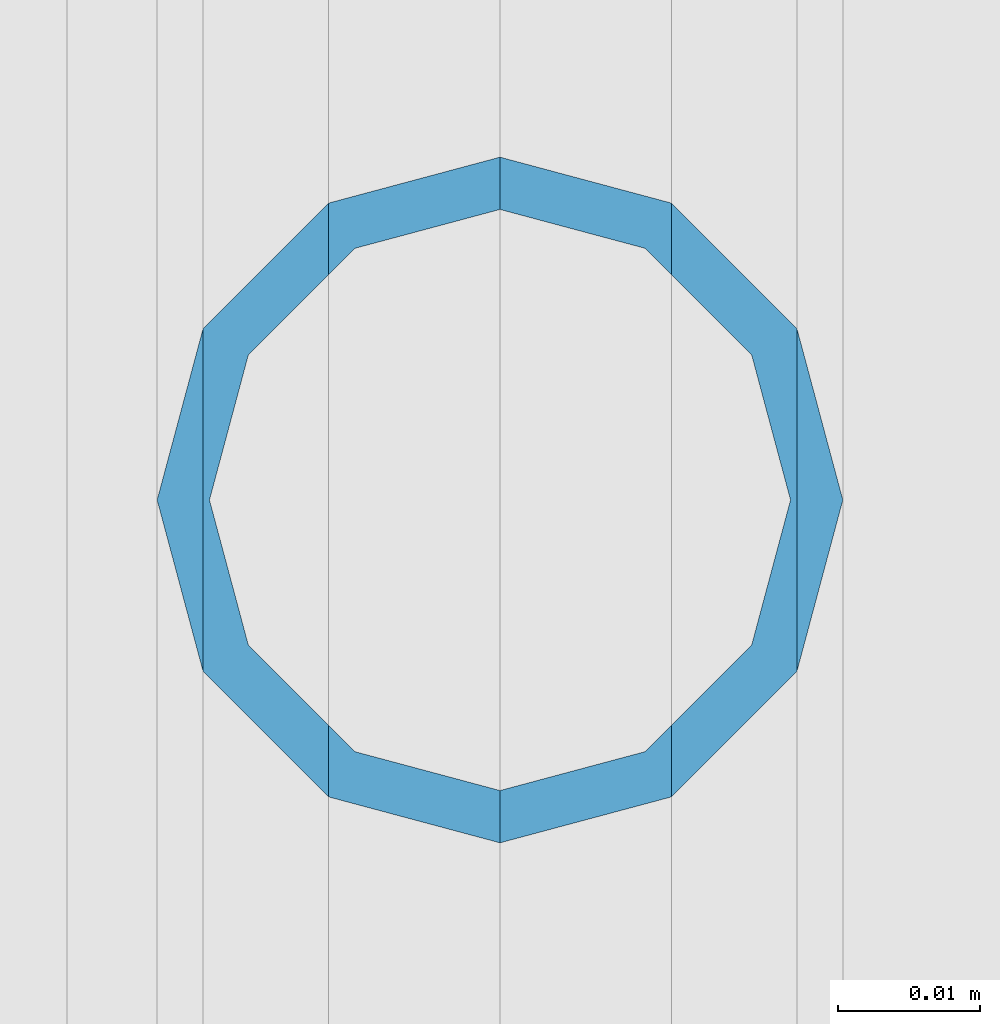
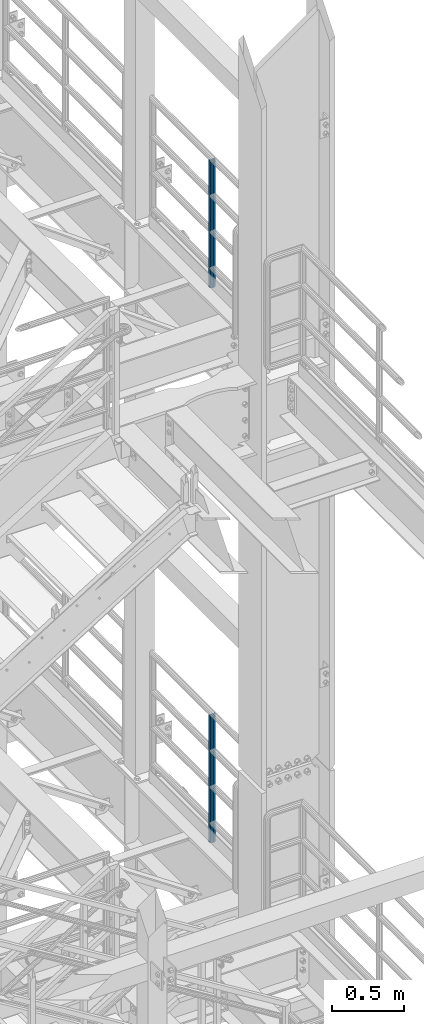
# One storey, part 669 of 1876: 2 columns, 2 elements without a shape of their own.
"""IFC2X3 building model written with IfcOpenShell, lengths in millimetres."""

from ifc_helpers import new_model, si_unit, frame, origin_with_axes, place, context, subcontext, project, spatial, faceted_brep, material, type_object, element, aggregate, save


model = new_model("IFC2X3")

# Units and contexts
model_context = context("Model", 3, precision=1e-05, world=origin_with_axes())
body_context = subcontext(model_context, "Body", "Model", "MODEL_VIEW")
ifc_project = project(units=[si_unit("LENGTHUNIT", "METRE", prefix="MILLI"), si_unit("AREAUNIT", "SQUARE_METRE"), si_unit("VOLUMEUNIT", "CUBIC_METRE"), si_unit("MASSUNIT", "GRAM", prefix="KILO"), si_unit("TIMEUNIT", "SECOND"), si_unit("PLANEANGLEUNIT", "RADIAN"), si_unit("SOLIDANGLEUNIT", "STERADIAN"), si_unit("THERMODYNAMICTEMPERATUREUNIT", "DEGREE_CELSIUS"), si_unit("LUMINOUSINTENSITYUNIT", "LUMEN")], contexts=[model_context])

# Site, building, storey
site_placement = place(None, origin_with_axes())
site = spatial("IfcSite", under=ifc_project, at=site_placement, CompositionType="ELEMENT")
building_placement = place(site_placement, origin_with_axes())
building = spatial("IfcBuilding", under=site, at=building_placement, Name="Undefined", CompositionType="ELEMENT")
storey_placement = place(building_placement, origin_with_axes())
storey = spatial("IfcBuildingStorey", under=building, at=storey_placement, Name="Undefined", CompositionType="ELEMENT", Elevation=0.0)

# Assembly, column
assembly_1_placement = place(storey_placement, origin_with_axes())
assembly_1 = element("IfcElementAssembly", 1, at=assembly_1_placement, inside=storey, Name="RAIL", AssemblyPlace="NOTDEFINED", PredefinedType="RIGID_FRAME")
ifc_material = material()
column_type = type_object("IfcColumnType", Name="PIPE1-1/2SCH40", PredefinedType="NOTDEFINED")
column_1_placement = place(assembly_1_placement, frame((7620.0, -3542.7031, 17983.2), z_axis=(0.0, 1.0, 0.0), x_axis=(0.0, 0.0, 1.0)))
column_1 = element("IfcColumn", 2, at=column_1_placement, type_object=column_type, material=ifc_material, Name="POST", ObjectType="PIPE1-1/2SCH40", context=body_context, shape_type="Brep", body=[
    faceted_brep([(1055.42780700668, -12.0650000000001, 20.8971929933186), (1055.42780700668, -12.0650000000001, 15.8661214311805), (1054.93437856882, -10.2235000000001, 17.7076214311801), (1052.195, 0.0, 20.4470000000001), (1052.195, 0.0, 24.1300000000001), (1054.93437856882, 10.2235000000001, 17.7076214311801), (1055.42780700668, 12.0650000000001, 15.8661214311805), (1055.42780700668, 12.0650000000001, 20.8971929933186), (1076.325, 24.1300000000001, 0.0), (1064.26, 20.8971929933184, 12.0649999999996), (1064.25999999999, 20.8971929933186, -12.0649999999996), (1061.07042843786, 17.7076214311803, 10.2235000000001), (1063.80980700668, 20.4469999999999, 0.0), (1061.07042843786, 17.7076214311803, -10.2235000000001), (1055.42780700668, 12.0650000000001, -15.8661214311805), (1055.42780700667, 12.0649999999996, -20.8971929933186), (1054.93437856882, 10.2235000000001, -17.7076214311801), (1052.195, 0.0, -20.4470000000001), (1052.19499999999, 0.0, -24.1300000000001), (1055.42780700668, -12.0650000000001, -15.8661214311805), (1055.42780700667, -12.0649999999996, -20.8971929933186), (1054.93437856882, -10.2235000000001, -17.7076214311801), (1076.325, -24.1300000000001, 0.0), (1064.25999999999, -20.8971929933186, -12.0649999999996), (1064.26, -20.8971929933184, 12.0649999999996), (1061.07042843786, -17.7076214311803, -10.2235000000001), (1063.80980700668, -20.4469999999999, 0.0), (1061.07042843786, -17.7076214311803, 10.2235000000001), (0.0, -20.8971929933184, -12.0649999999996), (0.0, -12.0650000000001, -20.8971929933186), (-1.45519152283669e-11, 0.0, -24.130000000001), (0.0, 12.0650000000001, -20.8971929933186), (0.0, 20.8971929933184, -12.0649999999996), (0.0, 24.1299999999992, 0.0), (0.0, 20.8971929933184, 12.0649999999996), (0.0, 12.0650000000001, 20.8971929933186), (-1.45519152283669e-11, 0.0, 24.130000000001), (0.0, -12.0650000000001, 20.8971929933186), (0.0, -20.8971929933184, 12.0649999999996), (0.0, -24.1299999999992, 0.0), (0.0, -17.7076214311803, -10.2235000000001), (0.0, -10.2235000000001, -17.7076214311801), (-1.45519152283669e-11, 0.0, -20.4470000000001), (0.0, 10.2235000000001, -17.7076214311801), (0.0, 17.7076214311803, -10.2235000000001), (0.0, 20.4469999999999, 0.0), (0.0, 17.7076214311803, 10.2235000000001), (0.0, 10.2235000000001, 17.7076214311801), (-1.45519152283669e-11, 0.0, 20.4470000000001), (0.0, -10.2235000000001, 17.7076214311801), (0.0, -17.7076214311803, 10.2235000000001), (0.0, -20.4469999999999, 0.0)], [[[0, 1, 2, 3, 4]], [[4, 3, 5, 6, 7]], [[8, 9, 10]], [[7, 6, 11, 12, 13, 14, 15, 10, 9]], [[16, 17, 18, 15, 14]], [[19, 20, 18, 17, 21]], [[22, 23, 24]], [[24, 23, 20, 19, 25, 26, 27, 1, 0]], [[28, 29, 20, 23]], [[29, 30, 18, 20]], [[30, 31, 15, 18]], [[31, 32, 10, 15]], [[32, 33, 8, 10]], [[33, 34, 9, 8]], [[34, 35, 7, 9]], [[35, 36, 4, 7]], [[36, 37, 0, 4]], [[37, 38, 24, 0]], [[38, 39, 22, 24]], [[39, 28, 23, 22]], [[38, 37, 36, 35, 34, 33, 32, 31, 30, 29, 28, 39], [40, 41, 42, 43, 44, 45, 46, 47, 48, 49, 50, 51]], [[40, 51, 26, 25]], [[21, 41, 40, 25, 19]], [[42, 41, 21, 17]], [[43, 42, 17, 16]], [[44, 43, 16, 14, 13]], [[45, 44, 13, 12]], [[46, 45, 12, 11]], [[5, 47, 46, 11, 6]], [[48, 47, 5, 3]], [[49, 48, 3, 2]], [[50, 49, 2, 1, 27]], [[51, 50, 27, 26]]]),
])
aggregate(assembly_1, [column_1])

assembly_2_placement = place(storey_placement, origin_with_axes())
assembly_2 = element("IfcElementAssembly", 3, at=assembly_2_placement, inside=storey, Name="RAIL", AssemblyPlace="NOTDEFINED", PredefinedType="RIGID_FRAME")
column_2_placement = place(assembly_2_placement, frame((7620.0, -3542.70310000001, 13309.6), z_axis=(0.0, 1.0, 0.0), x_axis=(0.0, 0.0, 1.0)))
column_2 = element("IfcColumn", 4, at=column_2_placement, type_object=column_type, material=ifc_material, Name="POST", ObjectType="PIPE1-1/2SCH40", context=body_context, shape_type="Brep", body=[
    faceted_brep([(1055.42780700668, -12.0650000000001, 20.8971929933186), (1055.42780700668, -12.0650000000001, 15.8661214311805), (1054.93437856882, -10.2235000000001, 17.7076214311801), (1052.195, 0.0, 20.4470000000001), (1052.195, 0.0, 24.1300000000001), (1054.93437856882, 10.2235000000001, 17.7076214311801), (1055.42780700668, 12.0650000000001, 15.8661214311805), (1055.42780700668, 12.0650000000001, 20.8971929933186), (1076.325, 24.1300000000001, 0.0), (1064.26, 20.8971929933184, 12.0649999999996), (1064.25999999999, 20.8971929933186, -12.0649999999996), (1061.07042843786, 17.7076214311803, 10.2235000000001), (1063.80980700668, 20.4469999999999, 0.0), (1061.07042843786, 17.7076214311803, -10.2235000000001), (1055.42780700668, 12.0650000000001, -15.8661214311805), (1055.42780700667, 12.0649999999996, -20.8971929933186), (1054.93437856882, 10.2235000000001, -17.7076214311801), (1052.195, 0.0, -20.4470000000001), (1052.19499999999, 0.0, -24.1300000000001), (1055.42780700668, -12.0650000000001, -15.8661214311805), (1055.42780700667, -12.0649999999996, -20.8971929933186), (1054.93437856882, -10.2235000000001, -17.7076214311801), (1076.325, -24.1300000000001, 0.0), (1064.25999999999, -20.8971929933186, -12.0649999999996), (1064.26, -20.8971929933184, 12.0649999999996), (1061.07042843786, -17.7076214311803, -10.2235000000001), (1063.80980700668, -20.4469999999999, 0.0), (1061.07042843786, -17.7076214311803, 10.2235000000001), (0.0, -20.8971929933184, -12.0649999999996), (0.0, -12.0650000000001, -20.8971929933186), (-1.45519152283669e-11, 0.0, -24.130000000001), (0.0, 12.0650000000001, -20.8971929933186), (0.0, 20.8971929933184, -12.0649999999996), (0.0, 24.1299999999992, 0.0), (0.0, 20.8971929933184, 12.0649999999996), (0.0, 12.0650000000001, 20.8971929933186), (-1.45519152283669e-11, 0.0, 24.130000000001), (0.0, -12.0650000000001, 20.8971929933186), (0.0, -20.8971929933184, 12.0649999999996), (0.0, -24.1299999999992, 0.0), (0.0, -17.7076214311803, -10.2235000000001), (0.0, -10.2235000000001, -17.7076214311801), (-1.45519152283669e-11, 0.0, -20.4470000000001), (0.0, 10.2235000000001, -17.7076214311801), (0.0, 17.7076214311803, -10.2235000000001), (0.0, 20.4469999999999, 0.0), (0.0, 17.7076214311803, 10.2235000000001), (0.0, 10.2235000000001, 17.7076214311801), (-1.45519152283669e-11, 0.0, 20.4470000000001), (0.0, -10.2235000000001, 17.7076214311801), (0.0, -17.7076214311803, 10.2235000000001), (0.0, -20.4469999999999, 0.0)], [[[0, 1, 2, 3, 4]], [[4, 3, 5, 6, 7]], [[8, 9, 10]], [[7, 6, 11, 12, 13, 14, 15, 10, 9]], [[16, 17, 18, 15, 14]], [[19, 20, 18, 17, 21]], [[22, 23, 24]], [[24, 23, 20, 19, 25, 26, 27, 1, 0]], [[28, 29, 20, 23]], [[29, 30, 18, 20]], [[30, 31, 15, 18]], [[31, 32, 10, 15]], [[32, 33, 8, 10]], [[33, 34, 9, 8]], [[34, 35, 7, 9]], [[35, 36, 4, 7]], [[36, 37, 0, 4]], [[37, 38, 24, 0]], [[38, 39, 22, 24]], [[39, 28, 23, 22]], [[38, 37, 36, 35, 34, 33, 32, 31, 30, 29, 28, 39], [40, 41, 42, 43, 44, 45, 46, 47, 48, 49, 50, 51]], [[40, 51, 26, 25]], [[21, 41, 40, 25, 19]], [[42, 41, 21, 17]], [[43, 42, 17, 16]], [[44, 43, 16, 14, 13]], [[45, 44, 13, 12]], [[46, 45, 12, 11]], [[5, 47, 46, 11, 6]], [[48, 47, 5, 3]], [[49, 48, 3, 2]], [[50, 49, 2, 1, 27]], [[51, 50, 27, 26]]]),
])
aggregate(assembly_2, [column_2])

save(model, "model.ifc")
